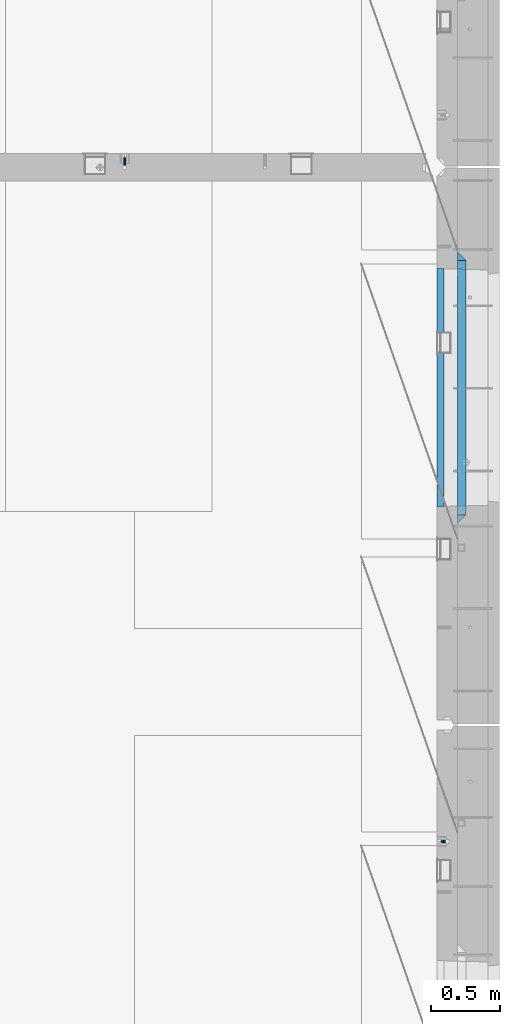
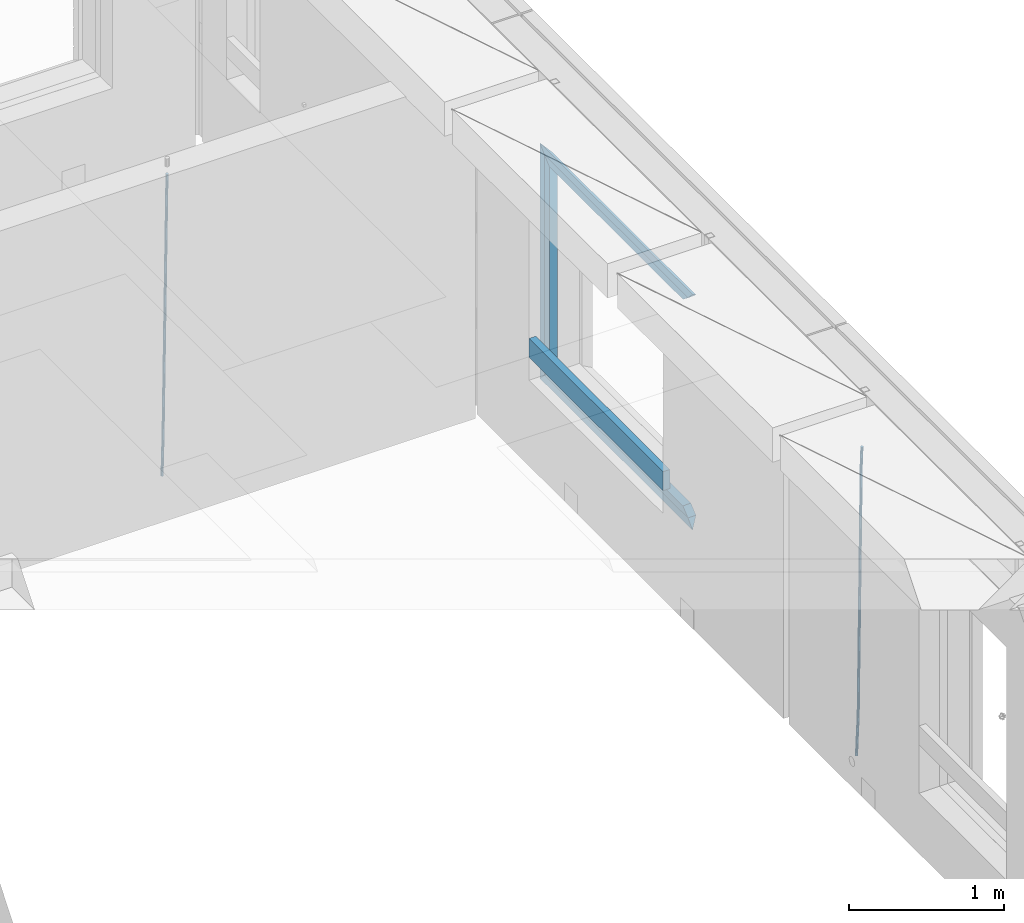
# One storey, part 132 of 349: 9 beams, 3 elements without a shape of their own.
"""IFC2X3 building model written with IfcOpenShell, lengths in millimetres."""

from ifc_helpers import new_model, si_unit, frame, origin_with_axes, place, context, subcontext, project, spatial, faceted_brep, material, type_object, element, aggregate, save


model = new_model("IFC2X3")

# Units and contexts
model_context = context("Model", 3, precision=1e-05, world=origin_with_axes())
body_context = subcontext(model_context, "Body", "Model", "MODEL_VIEW")
ifc_project = project(units=[si_unit("LENGTHUNIT", "METRE", prefix="MILLI"), si_unit("AREAUNIT", "SQUARE_METRE"), si_unit("VOLUMEUNIT", "CUBIC_METRE"), si_unit("MASSUNIT", "GRAM", prefix="KILO"), si_unit("TIMEUNIT", "SECOND"), si_unit("PLANEANGLEUNIT", "RADIAN"), si_unit("SOLIDANGLEUNIT", "STERADIAN"), si_unit("THERMODYNAMICTEMPERATUREUNIT", "DEGREE_CELSIUS"), si_unit("LUMINOUSINTENSITYUNIT", "LUMEN")], contexts=[model_context])

# Site, building, storey
site_placement = place(None, origin_with_axes())
site = spatial("IfcSite", under=ifc_project, at=site_placement, CompositionType="ELEMENT")
building_placement = place(site_placement, origin_with_axes())
building = spatial("IfcBuilding", under=site, at=building_placement, CompositionType="ELEMENT")
storey_placement = place(building_placement, origin_with_axes())
storey = spatial("IfcBuildingStorey", under=building, at=storey_placement, Name="4", CompositionType="ELEMENT", Elevation=0.0)

# Assembly, beam
assembly_1_placement = place(storey_placement, origin_with_axes())
assembly_1 = element("IfcElementAssembly", 1, at=assembly_1_placement, inside=storey, AssemblyPlace="NOTDEFINED", PredefinedType="REINFORCEMENT_UNIT")
ifc_material_1 = material()
beam_type_1 = type_object("IfcBeamType", Name="D20", PredefinedType="NOTDEFINED")
beam_1_placement = place(assembly_1_placement, frame((32639.9999999961, 17044.9997581385, 90990.0), z_axis=(0.00020576299992186, -0.999642804629538, -0.0267249099901004), x_axis=(-4.30000201928125e-08, -0.0267249099948059, 0.999642825806181)))
beam_1 = element("IfcBeam", 2, at=beam_1_placement, type_object=beam_type_1, material=ifc_material_1, Name="JM20", ObjectType="D20", context=body_context, shape_type="Brep", body=[
    faceted_brep([(0.0, -10.0, 0.0), (-4.19531716033816e-08, -7.07106781186667, -7.07106781187031), (60.4266690400545, -7.0710677960451, -7.07106780570757), (60.4266690441291, -9.99999998418934, 6.15546014159918e-09), (0.0, 0.0, -10.0), (60.426669036824, 1.58106558956206e-08, -9.99999999384454), (4.196772351861e-08, 7.07106781186303, -7.07106781186667), (60.4266690363438, 7.07106782768096, -7.07106780570757), (0.0, 10.0, 0.0), (60.4266690388904, 10.0000000158179, 6.15182216279209e-09), (4.196772351861e-08, 7.07106781185939, 7.07106781185939), (60.4266690429649, 7.07106782768096, 7.07106781802577), (0.0, 0.0, 10.0), (60.4266690461809, 1.58179318532348e-08, 10.0000000061555), (-4.19531716033816e-08, -7.07106781187031, 7.07106781185939), (60.4266690466611, -7.07106779605238, 7.07106781802213), (61.0378400410118, -7.07106779588503, -7.07106780564936), (60.991799419251, -9.99999998403655, 6.21366780251265e-09), (61.0569027789461, 1.5985278878361e-08, -9.99999999378269), (61.0378209396877, 7.07106782784831, -7.07106780564936), (60.9917724058905, 10.0000000159635, 6.21366780251265e-09), (60.9457317841297, 7.07106782781193, 7.0710678180767), (60.9266690461809, 1.59488990902901e-08, 10.0000000062028), (60.9457508854539, -7.07106779591413, 7.0710678180767), (61.6489592143771, -7.07106614513759, -7.06310863441468), (61.5568818710308, -9.9999984576425, 0.00735959856683621), (61.6870830769039, 1.71821739058942e-06, -9.99179257185824), (61.6489210170112, 7.07106947854481, -7.06310888312146), (61.556827851804, 10.0000015422847, 0.00735924683976918), (61.4647505084577, 7.07106922979438, 7.07782747982128), (61.4266266459163, 1.36643211590126e-06, 10.0065114172685), (61.464788705809, -7.07106639389531, 7.07782772852806), (176.543135720174, -7.07075579406956, -5.56673531796696), (176.451058376813, -9.99968810657447, 1.50373291501455), (176.581259582701, 0.000312069292704109, -8.49541925541052), (176.543097522794, 7.07137982961285, -5.56673556667374), (176.451004357587, 10.00031189336, 1.50373256329476), (176.35892701424, 7.07137958085514, 8.57420079627263), (176.320803151699, 0.000311717507429421, 11.5028847337162), (176.358965211621, -7.07075604281999, 8.57420104497578), (177.098753836006, -7.07075429323595, -5.55949898843028), (176.98362511232, -9.99968666800123, 1.510669025065), (177.146421932586, 0.000313595905026887, -8.48805862247536), (177.098706077581, 7.07138133041735, -5.55949936166144), (176.983557571715, 10.0003133318824, 1.51066849724157), (176.868428848029, 7.07138095712435, 8.58083651073321), (176.820760751449, 0.000313067976094317, 11.5093961447819), (176.868476606425, -7.07075466652896, 8.58083688396073), (177.654312950661, -7.07075204110879, -5.54863964998367), (177.516135294456, -9.99968450931192, 1.52107783331303), (177.711524267797, 0.000315886711177882, -8.47701274570863), (177.654255632195, 7.07138358250813, -5.54864021007961), (177.516054233929, 10.0003154905207, 1.5210770412159), (177.377876577739, 7.0713830223176, 8.59079452451624), (177.320665260588, 0.000315094497636892, 11.5191676202448), (177.377933896176, -7.07075260129932, 8.59079508461218), (299.499456785634, -7.07025810522464, -3.16697112782276), (299.361279129444, -9.99919057342777, 3.90274635547394), (299.556668102785, 0.000809822595329024, -6.09534422354773), (299.499399467197, 7.07187751838501, -3.1669716879187), (299.361198068917, 10.0008094264049, 3.90274556338045), (299.223020412712, 7.07187695819448, 10.9724630466735), (299.165809095575, 0.000809030381788034, 13.9008361423985), (299.223077731163, -7.07025866542244, 10.9724636067695), (300.03174732349, -7.07025594743027, -3.15656661289177), (299.971788958996, -9.99918809853989, 3.91467979818117), (300.056572611924, 0.000811849109595641, -6.08557274808481), (300.031722507032, 7.07187967631762, -3.15656653768019), (299.971753863239, 10.0008119014747, 3.91467990454839), (299.91179549876, 7.07187975035777, 10.9859263156177), (299.886970210311, 0.000811953817901667, 13.9149324508144), (299.911820315203, -7.0702558733974, 10.9859262404061), (300.564137759997, -7.07025623699155, -3.15794273276697), (300.582413367199, -9.99918843065097, 3.91310145956595), (300.556570941641, 0.000811577163403854, -6.0868651410201), (300.564145451674, 7.07187938674906, -3.15794274158179), (300.582424244858, 10.0008115693345, 3.91310144710224), (300.600699852032, 7.07187937566778, 10.9841456394352), (300.608266670402, 0.000811561512819026, 13.9130680476919), (300.600692160384, -7.07025624805829, 10.98414564825), (2294.16589219622, -7.0713405251372, -8.31099358700158), (2294.1841678034, -10.0002727187966, -1.23994939466866), (2294.15832537785, -0.000272710982244462, -11.2399159952547), (2294.16589988787, 7.07079509858886, -8.31099359582004), (2294.18417868105, 9.99972728118883, -1.23994940713601), (2294.20245428824, 7.07079508752213, 5.83109478519327), (2294.2100211066, -0.00027272663282929, 8.76001719345368), (2294.20244659658, -7.07134053620393, 5.83109479401173), (2294.7782683276, -7.07134085819416, -8.31257645345977), (2294.72126025338, -10.000273010919, -1.24133766827799), (2294.84007459224, -0.000273081772320438, -11.2416781768807), (2294.87047377572, 7.07079471537872, -8.31281477453012), (2294.85165844864, 9.9997269181622, -1.24167470516841), (2294.7946503744, 7.07079476544459, 5.82956408001337), (2294.73284410976, -0.000273010977252852, 8.75866580342336), (2294.7024449263, -7.07134080815013, 5.82980240107645), (2295.39054023061, -7.0793250091956, -8.30442771922026), (2295.25826128852, -10.0072756143927, -1.23419071494573), (2295.52170777075, -0.00916171800054144, -11.2326063125765), (2295.57492774284, 7.06160849139269, -8.30343918807193), (2295.51902460904, 9.99102432676591, -1.23279272078435), (2295.38674566693, 7.06307372157607, 5.83744428349019), (2295.25557812679, -0.0070895696117077, 8.76562287684646), (2295.20235815471, -7.07785977901949, 5.83645575234186), (2317.1947101649, -7.36365585014573, -8.01423575520312), (2317.06243122277, -10.2916064553428, -0.94399875092131), (2317.32587770502, -0.293492558957951, -10.9424143485521), (2317.37909767711, 6.77727765044983, -8.01324722405116), (2317.32319454331, 9.70669348581578, -0.942600756767206), (2317.1909156012, 6.77874288063322, 6.12763624751096), (2317.05974806109, -0.291420410569117, 9.0558148408636), (2317.00652808898, -7.36219061996962, 6.12664771636264), (2317.83015404257, -7.37194216843636, -8.00577862486898), (2317.72252095213, -10.300214160583, -0.935213608652703), (2317.90419832576, -0.301033978277701, -10.9347174723516), (2317.90127966482, 6.77046829039318, -8.00629749759901), (2317.82310777172, 9.70017451494641, -0.935947405505431), (2317.71547468127, 6.77190252279979, 6.13461761071085), (2317.64143039809, -0.29900566735887, 9.06355645819713), (2317.64434905903, -7.37050793602975, 6.13513648344451), (2318.46565174212, -7.3700661537805, -7.99751648408346), (2318.38266643914, -10.2982456018653, -0.926623872735945), (2318.48256818345, -0.299336209594912, -10.9272153854981), (2318.42350634121, 6.77200652527245, -7.99954269419686), (2318.32306384158, 9.70166538090416, -0.929489366557391), (2318.2400785386, 6.77348593281204, 6.14140324480104), (2318.22316209726, -0.297244011366274, 9.07110214621207), (2318.2822239395, -7.36858674623363, 6.1434294549108), (2418.48643733139, -7.07180401323421, -6.70013846199799), (2418.4034520284, -9.99998346132634, 0.370754149349523), (2418.5033537727, -0.00107406904135132, -9.62983736341266), (2418.44429193046, 7.07026866581873, -6.70216467211139), (2418.34384943081, 9.99992752145772, 0.367888655531715), (2418.26086412782, 7.0717480733656, 7.43878126688651), (2418.24394768651, 0.00101812917273492, 10.3684801682975), (2418.30300952874, -7.07032460568735, 7.44080747699627)], [[[0, 1, 2, 3]], [[1, 4, 5, 2]], [[4, 6, 7, 5]], [[6, 8, 9, 7]], [[8, 10, 11, 9]], [[10, 12, 13, 11]], [[12, 14, 15, 13]], [[14, 0, 3, 15]], [[14, 12, 10, 8, 6, 4, 1, 0]], [[3, 2, 16, 17]], [[2, 5, 18, 16]], [[5, 7, 19, 18]], [[7, 9, 20, 19]], [[9, 11, 21, 20]], [[11, 13, 22, 21]], [[13, 15, 23, 22]], [[15, 3, 17, 23]], [[17, 16, 24, 25]], [[16, 18, 26, 24]], [[18, 19, 27, 26]], [[19, 20, 28, 27]], [[20, 21, 29, 28]], [[21, 22, 30, 29]], [[22, 23, 31, 30]], [[23, 17, 25, 31]], [[25, 24, 32, 33]], [[24, 26, 34, 32]], [[26, 27, 35, 34]], [[27, 28, 36, 35]], [[28, 29, 37, 36]], [[29, 30, 38, 37]], [[30, 31, 39, 38]], [[31, 25, 33, 39]], [[33, 32, 40, 41]], [[32, 34, 42, 40]], [[34, 35, 43, 42]], [[35, 36, 44, 43]], [[36, 37, 45, 44]], [[37, 38, 46, 45]], [[38, 39, 47, 46]], [[39, 33, 41, 47]], [[41, 40, 48, 49]], [[40, 42, 50, 48]], [[42, 43, 51, 50]], [[43, 44, 52, 51]], [[44, 45, 53, 52]], [[45, 46, 54, 53]], [[46, 47, 55, 54]], [[47, 41, 49, 55]], [[49, 48, 56, 57]], [[48, 50, 58, 56]], [[50, 51, 59, 58]], [[51, 52, 60, 59]], [[52, 53, 61, 60]], [[53, 54, 62, 61]], [[54, 55, 63, 62]], [[55, 49, 57, 63]], [[57, 56, 64, 65]], [[56, 58, 66, 64]], [[58, 59, 67, 66]], [[59, 60, 68, 67]], [[60, 61, 69, 68]], [[61, 62, 70, 69]], [[62, 63, 71, 70]], [[63, 57, 65, 71]], [[65, 64, 72, 73]], [[64, 66, 74, 72]], [[66, 67, 75, 74]], [[67, 68, 76, 75]], [[68, 69, 77, 76]], [[69, 70, 78, 77]], [[70, 71, 79, 78]], [[71, 65, 73, 79]], [[73, 72, 80, 81]], [[72, 74, 82, 80]], [[74, 75, 83, 82]], [[75, 76, 84, 83]], [[76, 77, 85, 84]], [[77, 78, 86, 85]], [[78, 79, 87, 86]], [[79, 73, 81, 87]], [[81, 80, 88, 89]], [[80, 82, 90, 88]], [[82, 83, 91, 90]], [[83, 84, 92, 91]], [[84, 85, 93, 92]], [[85, 86, 94, 93]], [[86, 87, 95, 94]], [[87, 81, 89, 95]], [[89, 88, 96, 97]], [[88, 90, 98, 96]], [[90, 91, 99, 98]], [[91, 92, 100, 99]], [[92, 93, 101, 100]], [[93, 94, 102, 101]], [[94, 95, 103, 102]], [[95, 89, 97, 103]], [[97, 96, 104, 105]], [[96, 98, 106, 104]], [[98, 99, 107, 106]], [[99, 100, 108, 107]], [[100, 101, 109, 108]], [[101, 102, 110, 109]], [[102, 103, 111, 110]], [[103, 97, 105, 111]], [[105, 104, 112, 113]], [[104, 106, 114, 112]], [[106, 107, 115, 114]], [[107, 108, 116, 115]], [[108, 109, 117, 116]], [[109, 110, 118, 117]], [[110, 111, 119, 118]], [[111, 105, 113, 119]], [[113, 112, 120, 121]], [[112, 114, 122, 120]], [[114, 115, 123, 122]], [[115, 116, 124, 123]], [[116, 117, 125, 124]], [[117, 118, 126, 125]], [[118, 119, 127, 126]], [[119, 113, 121, 127]], [[121, 120, 128, 129]], [[120, 122, 130, 128]], [[122, 123, 131, 130]], [[123, 124, 132, 131]], [[124, 125, 133, 132]], [[125, 126, 134, 133]], [[126, 127, 135, 134]], [[127, 121, 129, 135]], [[130, 131, 132, 133, 134, 135, 129, 128]]]),
])
aggregate(assembly_1, [beam_1])

assembly_2_placement = place(storey_placement, origin_with_axes())
assembly_2 = element("IfcElementAssembly", 3, at=assembly_2_placement, inside=storey, AssemblyPlace="NOTDEFINED", PredefinedType="REINFORCEMENT_UNIT")
beam_2_placement = place(assembly_2_placement, frame((34944.9999977209, 12080.9402860984, 90990.0), z_axis=(0.999642804629538, 0.000205762999925497, -0.0267249099901003), x_axis=(0.0267249109941254, -4.30000210532798e-08, 0.999642825779465)))
beam_2 = element("IfcBeam", 4, at=beam_2_placement, type_object=beam_type_1, material=ifc_material_1, Name="JM20", ObjectType="D20", context=body_context, shape_type="Brep", body=[
    faceted_brep([(0.0, -10.0, 0.0), (-4.19531716033816e-08, -7.07106781186667, -7.07106781187031), (60.4266690400545, -7.0710677960451, -7.07106780570757), (60.4266690441291, -9.99999998418934, 6.15546014159918e-09), (0.0, 0.0, -10.0), (60.426669036824, 1.58106558956206e-08, -9.99999999384454), (4.196772351861e-08, 7.07106781186303, -7.07106781186667), (60.4266690363438, 7.07106782768096, -7.07106780570757), (0.0, 10.0, 0.0), (60.4266690388904, 10.0000000158179, 6.15182216279209e-09), (4.196772351861e-08, 7.07106781185939, 7.07106781185939), (60.4266690429649, 7.07106782768096, 7.07106781802577), (0.0, 0.0, 10.0), (60.4266690461809, 1.58179318532348e-08, 10.0000000061555), (-4.19531716033816e-08, -7.07106781187031, 7.07106781185939), (60.4266690466611, -7.07106779605238, 7.07106781802213), (61.0378400410118, -7.07106779588503, -7.07106780564936), (60.991799419251, -9.99999998403655, 6.21366780251265e-09), (61.0569027789461, 1.5985278878361e-08, -9.99999999378269), (61.0378209396877, 7.07106782784831, -7.07106780564936), (60.9917724058905, 10.0000000159635, 6.21366780251265e-09), (60.9457317841297, 7.07106782781193, 7.0710678180767), (60.9266690461809, 1.59488990902901e-08, 10.0000000062028), (60.9457508854539, -7.07106779591413, 7.0710678180767), (61.6489592143771, -7.07106614513759, -7.06310863441468), (61.5568818710308, -9.9999984576425, 0.00735959856683621), (61.6870830769039, 1.71821739058942e-06, -9.99179257185824), (61.6489210170112, 7.07106947854481, -7.06310888312146), (61.556827851804, 10.0000015422847, 0.00735924683976918), (61.4647505084577, 7.07106922979438, 7.07782747982128), (61.4266266459163, 1.36643211590126e-06, 10.0065114172685), (61.464788705809, -7.07106639389531, 7.07782772852806), (176.543135720174, -7.07075579406956, -5.56673531796696), (176.451058376813, -9.99968810657447, 1.50373291501455), (176.581259582701, 0.000312069292704109, -8.49541925541052), (176.543097522794, 7.07137982961285, -5.56673556667374), (176.451004357587, 10.00031189336, 1.50373256329476), (176.35892701424, 7.07137958085514, 8.57420079627263), (176.320803151699, 0.000311717507429421, 11.5028847337162), (176.358965211621, -7.07075604281999, 8.57420104497578), (177.098753836006, -7.07075429323595, -5.55949898843028), (176.98362511232, -9.99968666800123, 1.510669025065), (177.146421932586, 0.000313595905026887, -8.48805862247536), (177.098706077581, 7.07138133041735, -5.55949936166144), (176.983557571715, 10.0003133318824, 1.51066849724157), (176.868428848029, 7.07138095712435, 8.58083651073321), (176.820760751449, 0.000313067976094317, 11.5093961447819), (176.868476606425, -7.07075466652896, 8.58083688396073), (177.654312950661, -7.07075204110879, -5.54863964998367), (177.516135294456, -9.99968450931192, 1.52107783331303), (177.711524267797, 0.000315886711177882, -8.47701274570863), (177.654255632195, 7.07138358250813, -5.54864021007961), (177.516054233929, 10.0003154905207, 1.5210770412159), (177.377876577739, 7.0713830223176, 8.59079452451624), (177.320665260588, 0.000315094497636892, 11.5191676202448), (177.377933896176, -7.07075260129932, 8.59079508461218), (299.436796249574, -7.07025836271714, -3.1681962331204), (299.298618593355, -9.99919083092027, 3.90152125031091), (299.494007566798, 0.000809565110102994, -6.09656932889993), (299.436738931283, 7.07187726089978, -3.16819679320906), (299.298537533061, 10.0008091689197, 3.90152045822106), (299.160359876842, 7.07187670072017, 10.9712379416487), (299.103148559603, 0.000808772889286047, 13.8996110374392), (299.160417195119, -7.07025892290039, 10.9712385017483), (299.98743051647, -7.07025613056248, -3.15743315966392), (299.971788958996, -9.99918809853989, 3.91467979818117), (299.993912075952, 0.000811591617093654, -6.08679785393178), (299.987423933868, 7.07187949325817, -3.1574327280432), (299.971753863239, 10.0008119014747, 3.91467990454839), (299.95611230444, 7.07187992653053, 10.9867922621015), (299.949630744944, 0.000812204350950196, 13.9161569563694), (299.956118887014, -7.07025569729012, 10.9867918304735), (300.538107039494, -7.07025785017686, -3.16575821840888), (300.644985195438, -9.99919020432935, 3.90450175465594), (300.493854948218, 0.000810030429420294, -6.09435592770024), (300.538151196495, 7.071877773491, -3.16575855385963), (300.645047642858, 10.0008097955724, 3.90450128024895), (300.751925798773, 7.07187744142357, 10.9747612533101), (300.796177890064, 0.000809560813650023, 13.9033589625978), (300.751881641787, -7.07025818224065, 10.9747615887682), (2293.36490490142, -7.07648090940347, -33.2930642912361), (2293.47178305736, -10.0054132635523, -26.2228043181785), (2293.32065281013, -0.00541302880083094, -36.2216620005347), (2293.36494905842, 7.06565471425711, -33.2930646266868), (2293.47184550477, 9.99458673634581, -26.2228047925819), (2293.57872366071, 7.06565438219332, -19.1525448195243), (2293.62297575199, -0.00541349841296324, -16.2239471102366), (2293.57867950371, -7.0764812414709, -19.1525444840736), (2294.0658245362, -7.07648309818615, -33.3036607065333), (2294.05312277409, -10.0054150789219, -26.2315929392535), (2294.10928714235, -0.00541549149056664, -36.2335844756526), (2294.15805078732, 7.06565223761572, -33.3050546393533), (2294.18355038921, 9.99458451388637, -26.2335642579346), (2294.17084862708, 7.06565253314329, -19.1614964906439), (2294.12738602093, -0.00541507354500936, -16.2315727215355), (2294.07862237596, -7.07648280265857, -19.1601025578348), (2294.76670261032, -7.08562269121467, -33.294332712383), (2294.63442802057, -10.0129954178956, -26.2238563411993), (2294.89787471293, -0.0156988342423574, -36.2230891548279), (2294.95110548967, 7.05531064255774, -33.2944998654275), (2294.89521307347, 9.98530428734011, -26.2240927312887), (2294.76293848372, 7.0579315606592, -19.1536163601049), (2294.63176638114, -0.0119922963167483, -16.2248599176673), (2294.57853560438, -7.08300177311321, -19.1534492070678), (2316.52657204497, -7.36937582653991, -33.0047303660212), (2316.39429745522, -10.2967485532172, -25.9342539948302), (2316.65774414754, -0.299451969567599, -35.9334868084661), (2316.7109749243, 6.7715575072325, -33.0048975190657), (2316.65508250811, 9.70155115201487, -25.9344903849269), (2316.52280791836, 6.7741784253376, -18.8640140137468), (2316.39163581574, -0.295745431634714, -15.9352575713092), (2316.33840503903, -7.36675490843481, -18.863846860706), (2317.16202064224, -7.37766220584308, -32.9962731735213), (2317.05438744847, -10.3053562613532, -25.9254688497131), (2317.23607125619, -0.306993473008333, -35.925789846493), (2317.23316144495, 6.76474808850253, -32.9979477328052), (2317.15499573652, 9.6950321815566, -25.9278370341635), (2317.04736254275, 6.7673381260538, -18.8570327103698), (2316.97331192881, -0.303330606784584, -15.9275160373909), (2316.97622174003, -7.37507216829545, -18.8553581510787), (2317.79752306276, -7.37578610372293, -32.9880110666527), (2317.71453320107, -10.3033876998124, -25.9168792378296), (2317.81444760226, -0.305295583297266, -35.918287695793), (2317.75539265381, 6.76628640723357, -32.9911928173897), (2317.65495180529, 9.69652304524061, -25.9213789128698), (2317.5719619436, 6.76892144914746, -18.8502470840467), (2317.55503740412, -0.301569071270933, -15.9199704549137), (2317.61409235255, -7.3731510618054, -18.847065333317), (2417.8183084176, -7.07752398473531, -31.6906369377139), (2417.73531855589, -10.0051255808248, -24.6195051088798), (2417.83523295709, -0.007033464313281, -34.6209135668432), (2417.77617800863, 7.06454852621755, -31.6938186884508), (2417.67573716014, 9.99478516423187, -24.6240047839383), (2417.59274729842, 7.06718356813872, -17.5528729551006), (2417.57582275895, -0.00330695228694822, -14.6225963259749), (2417.6348777074, -7.07488894281778, -17.5496912043673)], [[[0, 1, 2, 3]], [[1, 4, 5, 2]], [[4, 6, 7, 5]], [[6, 8, 9, 7]], [[8, 10, 11, 9]], [[10, 12, 13, 11]], [[12, 14, 15, 13]], [[14, 0, 3, 15]], [[14, 12, 10, 8, 6, 4, 1, 0]], [[3, 2, 16, 17]], [[2, 5, 18, 16]], [[5, 7, 19, 18]], [[7, 9, 20, 19]], [[9, 11, 21, 20]], [[11, 13, 22, 21]], [[13, 15, 23, 22]], [[15, 3, 17, 23]], [[17, 16, 24, 25]], [[16, 18, 26, 24]], [[18, 19, 27, 26]], [[19, 20, 28, 27]], [[20, 21, 29, 28]], [[21, 22, 30, 29]], [[22, 23, 31, 30]], [[23, 17, 25, 31]], [[25, 24, 32, 33]], [[24, 26, 34, 32]], [[26, 27, 35, 34]], [[27, 28, 36, 35]], [[28, 29, 37, 36]], [[29, 30, 38, 37]], [[30, 31, 39, 38]], [[31, 25, 33, 39]], [[33, 32, 40, 41]], [[32, 34, 42, 40]], [[34, 35, 43, 42]], [[35, 36, 44, 43]], [[36, 37, 45, 44]], [[37, 38, 46, 45]], [[38, 39, 47, 46]], [[39, 33, 41, 47]], [[41, 40, 48, 49]], [[40, 42, 50, 48]], [[42, 43, 51, 50]], [[43, 44, 52, 51]], [[44, 45, 53, 52]], [[45, 46, 54, 53]], [[46, 47, 55, 54]], [[47, 41, 49, 55]], [[49, 48, 56, 57]], [[48, 50, 58, 56]], [[50, 51, 59, 58]], [[51, 52, 60, 59]], [[52, 53, 61, 60]], [[53, 54, 62, 61]], [[54, 55, 63, 62]], [[55, 49, 57, 63]], [[57, 56, 64, 65]], [[56, 58, 66, 64]], [[58, 59, 67, 66]], [[59, 60, 68, 67]], [[60, 61, 69, 68]], [[61, 62, 70, 69]], [[62, 63, 71, 70]], [[63, 57, 65, 71]], [[65, 64, 72, 73]], [[64, 66, 74, 72]], [[66, 67, 75, 74]], [[67, 68, 76, 75]], [[68, 69, 77, 76]], [[69, 70, 78, 77]], [[70, 71, 79, 78]], [[71, 65, 73, 79]], [[73, 72, 80, 81]], [[72, 74, 82, 80]], [[74, 75, 83, 82]], [[75, 76, 84, 83]], [[76, 77, 85, 84]], [[77, 78, 86, 85]], [[78, 79, 87, 86]], [[79, 73, 81, 87]], [[81, 80, 88, 89]], [[80, 82, 90, 88]], [[82, 83, 91, 90]], [[83, 84, 92, 91]], [[84, 85, 93, 92]], [[85, 86, 94, 93]], [[86, 87, 95, 94]], [[87, 81, 89, 95]], [[89, 88, 96, 97]], [[88, 90, 98, 96]], [[90, 91, 99, 98]], [[91, 92, 100, 99]], [[92, 93, 101, 100]], [[93, 94, 102, 101]], [[94, 95, 103, 102]], [[95, 89, 97, 103]], [[97, 96, 104, 105]], [[96, 98, 106, 104]], [[98, 99, 107, 106]], [[99, 100, 108, 107]], [[100, 101, 109, 108]], [[101, 102, 110, 109]], [[102, 103, 111, 110]], [[103, 97, 105, 111]], [[105, 104, 112, 113]], [[104, 106, 114, 112]], [[106, 107, 115, 114]], [[107, 108, 116, 115]], [[108, 109, 117, 116]], [[109, 110, 118, 117]], [[110, 111, 119, 118]], [[111, 105, 113, 119]], [[113, 112, 120, 121]], [[112, 114, 122, 120]], [[114, 115, 123, 122]], [[115, 116, 124, 123]], [[116, 117, 125, 124]], [[117, 118, 126, 125]], [[118, 119, 127, 126]], [[119, 113, 121, 127]], [[121, 120, 128, 129]], [[120, 122, 130, 128]], [[122, 123, 131, 130]], [[123, 124, 132, 131]], [[124, 125, 133, 132]], [[125, 126, 134, 133]], [[126, 127, 135, 134]], [[127, 121, 129, 135]], [[130, 131, 132, 133, 134, 135, 129, 128]]]),
])
aggregate(assembly_2, [beam_2])

# Assembly, beams
assembly_3_placement = place(storey_placement, origin_with_axes())
assembly_3 = element("IfcElementAssembly", 5, at=assembly_3_placement, inside=storey, AssemblyPlace="NOTDEFINED", PredefinedType="REINFORCEMENT_UNIT")
ifc_material_2 = material(Name="TIMBER/T24")
beam_type_2 = type_object("IfcBeamType", PredefinedType="NOTDEFINED")
beam_3_placement = place(assembly_3_placement, frame((34935.0002758707, 14515.0011884524, 91685.0), z_axis=(0.0, 0.0, 1.0), x_axis=(0.0, 1.0, 0.0)))
beam_3 = element("IfcBeam", 6, at=beam_3_placement, type_object=beam_type_2, material=ifc_material_2, context=body_context, shape_type="Brep", body=[
    faceted_brep([(-3.63797880709171e-12, 24.9999999999964, -75.0), (-3.63797880709171e-12, 24.9999999999964, 75.0), (1730.0, 25.0, 75.0), (1730.0, 25.0, -75.0), (0.0, -25.0000000000073, 75.0), (1730.0, -25.0, 75.0), (0.0, -25.0000000000073, -75.0), (1730.0, -25.0, -75.0)], [[[0, 1, 2, 3]], [[1, 4, 5, 2]], [[4, 6, 7, 5]], [[6, 0, 3, 7]], [[5, 7, 3, 2]], [[6, 4, 1, 0]]]),
])
ifc_material_3 = material(Name="CONCRETE/C25/30")
beam_type_3 = type_object("IfcBeamType", PredefinedType="NOTDEFINED")
beam_4_placement = place(assembly_3_placement, frame((35090.0, 14394.9995850056, 93145.0), z_axis=(0.0, 0.0, -1.0), x_axis=(0.0, 1.0, 0.0)))
beam_4 = element("IfcBeam", 7, at=beam_4_placement, type_object=beam_type_3, material=ifc_material_3, Name="SK", context=body_context, shape_type="Brep", body=[
    faceted_brep([(60.0000000000073, 30.0, 30.0), (0.0, -30.0, -30.0), (60.0000000000073, -30.0, 30.0), (1910.00076293945, 30.0, 30.0), (1970.00076293945, -30.0, -30.0), (1910.00076293945, -30.0, 30.0)], [[[0, 1, 2]], [[1, 0, 3, 4]], [[2, 1, 4, 5]], [[0, 2, 5, 3]], [[4, 3, 5]]]),
])
beam_5_placement = place(assembly_3_placement, frame((35090.0, 14454.9995850056, 93085.0), z_axis=(0.0, 0.0, -1.0), x_axis=(0.0, 1.0, 0.0)))
beam_5 = element("IfcBeam", 8, at=beam_5_placement, type_object=beam_type_3, material=ifc_material_3, Name="SK", context=body_context, shape_type="Brep", body=[
    faceted_brep([(1785.9467088854, -30.0, 24.0540540540533), (1784.32508726378, 30.0, 25.6756756756804), (65.6764386151262, 30.0, 25.6756756756804), (64.0548169935064, -30.0, 24.0540540540533), (65.6764386151262, 30.0, 26.294090229203), (64.0548169935064, -30.0, 24.9041288395529), (0.0, 30.0, -30.0), (0.0, -30.0, -30.0), (1850.00076293945, 30.0, -30.0), (1850.00076293945, -30.0, -30.0), (1785.9467088854, -30.0, 24.9034748914128), (1784.32508726378, 30.0, 26.2934362810774)], [[[0, 1, 2, 3]], [[3, 2, 4, 5]], [[5, 4, 6, 7]], [[7, 6, 8, 9]], [[0, 3, 5, 7, 9, 10]], [[1, 0, 10, 11]], [[6, 4, 2, 1, 11, 8]], [[9, 8, 11, 10]]]),
])
beam_6_placement = place(assembly_3_placement, frame((35090.0, 16335.0003479451, 93175.0), z_axis=(0.0, -1.0, 0.0), x_axis=(0.0, 0.0, -1.0)))
beam_6 = element("IfcBeam", 9, at=beam_6_placement, type_object=beam_type_3, material=ifc_material_3, Name="SK", context=body_context, shape_type="Brep", body=[
    faceted_brep([(60.0000000000073, 30.0, 30.0), (0.0, -30.0, -30.0), (60.0000000000073, -30.0, 30.0), (1795.00000000001, 30.0, 30.0), (1855.0, -30.0, -30.0), (1795.00000000001, -30.0, 30.0)], [[[0, 1, 2]], [[3, 4, 1, 0]], [[4, 5, 2, 1]], [[5, 3, 0, 2]], [[5, 4, 3]]]),
])
beam_7_placement = place(assembly_3_placement, frame((35090.0, 16305.0003479451, 91410.0), z_axis=(0.0, 0.0, 1.0), x_axis=(0.0, -1.0, 0.0)))
beam_7 = element("IfcBeam", 10, at=beam_7_placement, type_object=beam_type_3, material=ifc_material_3, Name="SK", context=body_context, shape_type="Brep", body=[
    faceted_brep([(1785.94594594595, -30.0, 24.0540540540533), (1784.32432432433, 30.0, 25.6756756756804), (65.6756756756768, 30.0, 25.6756756756804), (64.0540540540533, -30.0, 24.0540540540533), (1785.94594594595, -30.0, 24.9041288395238), (1784.32432432433, 30.0, 26.2940902291739), (1850.00076293945, -30.0, -30.0), (1850.00076293945, 30.0, -30.0), (0.0, 30.0, -30.0), (65.6756756756768, 30.0, 26.293436281092), (64.0540540540533, -30.0, 24.9034748914419), (0.0, -30.0, -30.0)], [[[0, 1, 2, 3]], [[1, 0, 4, 5]], [[4, 6, 7, 5]], [[2, 1, 5, 7, 8, 9]], [[3, 2, 9, 10]], [[6, 4, 0, 3, 10, 11]], [[11, 8, 7, 6]], [[11, 10, 9, 8]]]),
])
beam_8_placement = place(assembly_3_placement, frame((35090.0, 16365.0003479451, 91350.0), z_axis=(0.0, 0.0, 1.0), x_axis=(0.0, -1.0, 0.0)))
beam_8 = element("IfcBeam", 11, at=beam_8_placement, type_object=beam_type_3, material=ifc_material_3, Name="SK", context=body_context, shape_type="Brep", body=[
    faceted_brep([(1970.00076293945, -30.0, -30.0), (1910.00076293945, 30.0, 30.0), (1910.00076293945, -30.0, 30.0), (60.0000000000073, 30.0, 30.0), (60.0000000000073, -30.0, 30.0), (0.0, -30.0, -30.0)], [[[0, 1, 2]], [[3, 4, 2, 1]], [[4, 5, 0, 2]], [[5, 3, 1, 0]], [[3, 5, 4]]]),
])
beam_type_4 = type_object("IfcBeamType", PredefinedType="NOTDEFINED")
beam_9_placement = place(assembly_3_placement, frame((35090.0, 16270.0003479451, 93115.0), z_axis=(0.0, -1.0, 0.0), x_axis=(0.0, 0.0, -1.0)))
beam_9 = element("IfcBeam", 12, at=beam_9_placement, type_object=beam_type_4, material=ifc_material_3, Name="SK", context=body_context, shape_type="Brep", body=[
    faceted_brep([(0.0, -30.0, -35.0), (54.9034748914273, -30.0, 29.0540540540533), (56.2934362811066, 30.0, 30.6756756756768), (0.0, 30.0, -35.0), (1735.0, 30.0, -35.0), (1735.0, -30.0, -35.0), (1680.09652510857, -30.0, 29.0540540540533), (1678.70656371891, 30.0, 30.6756756756768)], [[[0, 1, 2, 3]], [[4, 5, 0, 3]], [[1, 0, 5, 6]], [[2, 1, 6, 7]], [[3, 2, 7, 4]], [[5, 4, 7, 6]]]),
])
aggregate(assembly_3, [beam_3, beam_4, beam_5, beam_6, beam_9, beam_7, beam_8])

save(model, "model.ifc")
